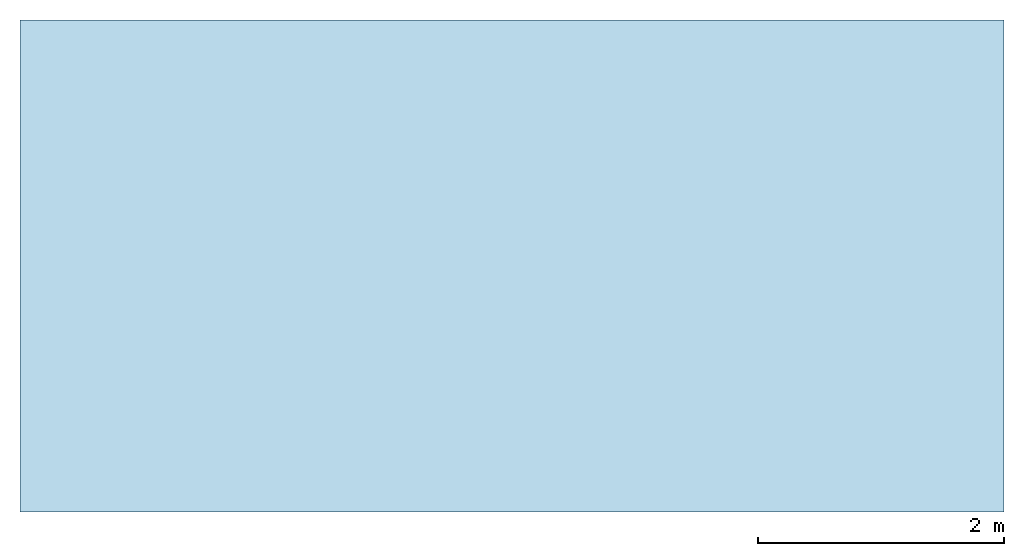
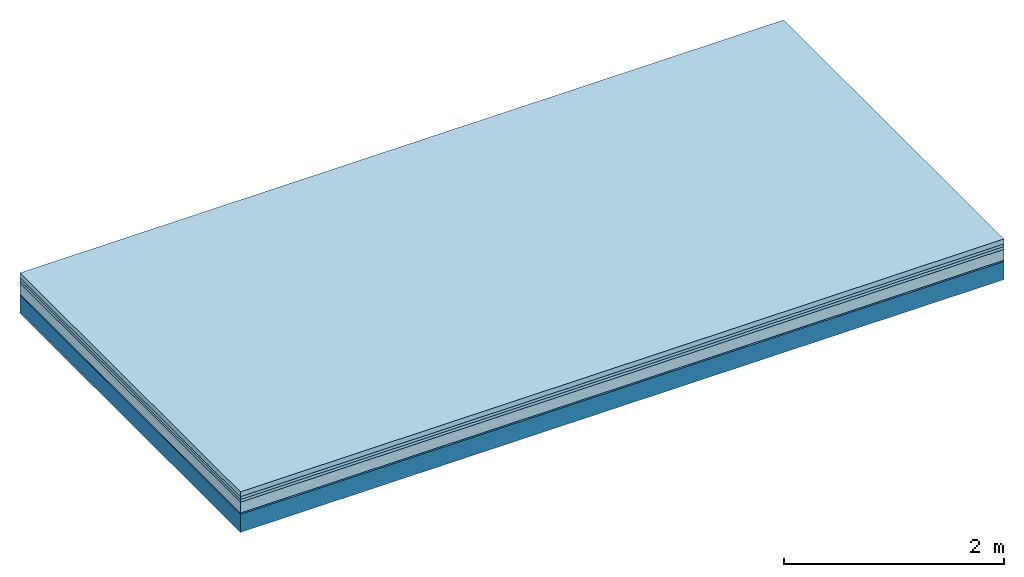
# One storey: 5 plates, 1 member, 1 element without a shape of its own.
"""IFC4 building model written with IfcOpenShell, lengths in metres."""

from ifc_helpers import new_model, si_unit, derived_unit, direction, frame, frame_2d, origin, origin_with_axes, place, context, project, spatial, rectangle, extrude, material, layer, layer_set, type_object, element, aggregate, save


model = new_model("IFC4")

# Units and contexts
plan_context = context("Plan", 3, precision=1e-05, world=origin(), true_north=direction((0.0, 1.0)))
model_context = context("Model", 3, precision=1e-05, world=origin(), true_north=direction((0.0, 1.0)))
ifc_project = project(units=[si_unit("LENGTHUNIT", "METRE"), derived_unit("SOUNDPRESSUREUNIT", [(si_unit("PRESSUREUNIT", "PASCAL", prefix="MICRO"), 0)]), si_unit("ENERGYUNIT", "JOULE", prefix="MEGA"), si_unit("MASSUNIT", "GRAM", prefix="KILO"), derived_unit("THERMALTRANSMITTANCEUNIT", [(si_unit("POWERUNIT", "WATT"), 1), (si_unit("AREAUNIT", "SQUARE_METRE"), -1), (si_unit("THERMODYNAMICTEMPERATUREUNIT", "KELVIN"), -1)]), derived_unit("AREADENSITYUNIT", [(si_unit("MASSUNIT", "GRAM", prefix="KILO"), 1), (si_unit("AREAUNIT", "SQUARE_METRE"), -1)]), derived_unit("USERDEFINED", [(si_unit("ENERGYUNIT", "JOULE", prefix="MEGA"), 1), (si_unit("AREAUNIT", "SQUARE_METRE"), -1)])], contexts=[plan_context, model_context])

# Site, building, storey
site = spatial("IfcSite", under=ifc_project)
building_placement = place(None, origin())
building = spatial("IfcBuilding", under=site, at=building_placement)
storey_placement = place(building_placement, origin())
storey = spatial("IfcBuildingStorey", under=building, at=storey_placement)

# Slab, member, plates
ifc_material_1 = material(Category="04.005")
ifc_layer_1 = layer(ifc_material_1, 0.055, Name="On-material")
ifc_material_2 = material()
ifc_layer_2 = layer(ifc_material_2, 0.03, Name="Impact sound insulation")
ifc_material_3 = material()
ifc_layer_3 = layer(ifc_material_3, 0.03, Name="Additional insulation")
ifc_material_4 = material(Category="03.011")
ifc_layer_4 = layer(ifc_material_4, 0.12, Name="on Supporting structure")
ifc_material_5 = material(Category="03.007")
ifc_layer_5 = layer(ifc_material_5, 0.015, Name="Sub-floor")
ifc_material_6 = material(Name="of the art")
ifc_layer_6 = layer(ifc_material_6, 0.0, Name="Bond")
ifc_layer_7 = layer(None, 0.2, Name="Supporting structure")
ifc_layer_set = layer_set([ifc_layer_1, ifc_layer_2, ifc_layer_3, ifc_layer_4, ifc_layer_5, ifc_layer_6, ifc_layer_7])
slab_type = type_object("IfcSlabType", Name="A1104", PredefinedType="NOTDEFINED", material=ifc_layer_set)
slab_placement = place(None, frame((0.0, 0.0, 0.0), z_axis=(0.0, 0.0, -1.0), x_axis=(1.0, 0.0, 0.0)))
slab = element("IfcSlab", 1, at=slab_placement, inside=storey, type_object=slab_type, material=ifc_layer_set, Name="Slab #1")
ifc_material_7 = material()
member_placement = place(slab_placement, origin())
member = element("IfcMember", 2, at=member_placement, material=ifc_material_7, Name="Supporting structure", context=plan_context, shape_type="SweptSolid", body=[
    extrude(rectangle(XDim=1.0, YDim=0.2, at=frame_2d((0.5, 0.1), x_axis=(1.0, 0.0))), frame((0.0, 4.0, 0.25), z_axis=(0.0, -1.0, 0.0), x_axis=(1.0, 0.0, 0.0)), (0.0, 0.0, 1.0), 4.0),
    extrude(rectangle(XDim=1.0, YDim=0.2, at=frame_2d((0.5, 0.1), x_axis=(1.0, 0.0))), frame((1.0, 4.0, 0.25), z_axis=(0.0, -1.0, 0.0), x_axis=(1.0, 0.0, 0.0)), (0.0, 0.0, 1.0), 4.0),
    extrude(rectangle(XDim=1.0, YDim=0.2, at=frame_2d((0.5, 0.1), x_axis=(1.0, 0.0))), frame((2.0, 4.0, 0.25), z_axis=(0.0, -1.0, 0.0), x_axis=(1.0, 0.0, 0.0)), (0.0, 0.0, 1.0), 4.0),
    extrude(rectangle(XDim=1.0, YDim=0.2, at=frame_2d((0.5, 0.1), x_axis=(1.0, 0.0))), frame((3.0, 4.0, 0.25), z_axis=(0.0, -1.0, 0.0), x_axis=(1.0, 0.0, 0.0)), (0.0, 0.0, 1.0), 4.0),
    extrude(rectangle(XDim=1.0, YDim=0.2, at=frame_2d((0.5, 0.1), x_axis=(1.0, 0.0))), frame((4.0, 4.0, 0.25), z_axis=(0.0, -1.0, 0.0), x_axis=(1.0, 0.0, 0.0)), (0.0, 0.0, 1.0), 4.0),
    extrude(rectangle(XDim=1.0, YDim=0.2, at=frame_2d((0.5, 0.1), x_axis=(1.0, 0.0))), frame((5.0, 4.0, 0.25), z_axis=(0.0, -1.0, 0.0), x_axis=(1.0, 0.0, 0.0)), (0.0, 0.0, 1.0), 4.0),
    extrude(rectangle(XDim=1.0, YDim=0.2, at=frame_2d((0.5, 0.1), x_axis=(1.0, 0.0))), frame((6.0, 4.0, 0.25), z_axis=(0.0, -1.0, 0.0), x_axis=(1.0, 0.0, 0.0)), (0.0, 0.0, 1.0), 4.0),
    extrude(rectangle(XDim=1.0, YDim=0.2, at=frame_2d((0.5, 0.1), x_axis=(1.0, 0.0))), frame((7.0, 4.0, 0.25), z_axis=(0.0, -1.0, 0.0), x_axis=(1.0, 0.0, 0.0)), (0.0, 0.0, 1.0), 4.0),
])
plate_1_placement = place(slab_placement, origin())
plate_1 = element("IfcPlate", 3, at=plate_1_placement, material=ifc_material_1, Name="On-material", context=plan_context, shape_type="SweptSolid", body=[
    extrude(rectangle(XDim=8.0, YDim=4.0, at=frame_2d((4.0, 2.0), x_axis=(1.0, 0.0))), origin_with_axes(), (0.0, 0.0, 1.0), 0.055),
])
plate_2_placement = place(slab_placement, origin())
plate_2 = element("IfcPlate", 4, at=plate_2_placement, material=ifc_material_2, Name="Impact sound insulation", context=plan_context, shape_type="SweptSolid", body=[
    extrude(rectangle(XDim=8.0, YDim=4.0, at=frame_2d((4.0, 2.0), x_axis=(1.0, 0.0))), frame((0.0, 0.0, 0.055), z_axis=(0.0, 0.0, 1.0), x_axis=(1.0, 0.0, 0.0)), (0.0, 0.0, 1.0), 0.03),
])
plate_3_placement = place(slab_placement, origin())
plate_3 = element("IfcPlate", 5, at=plate_3_placement, material=ifc_material_3, Name="Additional insulation", context=plan_context, shape_type="SweptSolid", body=[
    extrude(rectangle(XDim=8.0, YDim=4.0, at=frame_2d((4.0, 2.0), x_axis=(1.0, 0.0))), frame((0.0, 0.0, 0.085), z_axis=(0.0, 0.0, 1.0), x_axis=(1.0, 0.0, 0.0)), (0.0, 0.0, 1.0), 0.03),
])
plate_4_placement = place(slab_placement, origin())
plate_4 = element("IfcPlate", 6, at=plate_4_placement, material=ifc_material_4, Name="on Supporting structure", context=plan_context, shape_type="SweptSolid", body=[
    extrude(rectangle(XDim=8.0, YDim=4.0, at=frame_2d((4.0, 2.0), x_axis=(1.0, 0.0))), frame((0.0, 0.0, 0.115), z_axis=(0.0, 0.0, 1.0), x_axis=(1.0, 0.0, 0.0)), (0.0, 0.0, 1.0), 0.12),
])
plate_5_placement = place(slab_placement, origin())
plate_5 = element("IfcPlate", 7, at=plate_5_placement, material=ifc_material_5, Name="Sub-floor", context=plan_context, shape_type="SweptSolid", body=[
    extrude(rectangle(XDim=8.0, YDim=4.0, at=frame_2d((4.0, 2.0), x_axis=(1.0, 0.0))), frame((0.0, 0.0, 0.235), z_axis=(0.0, 0.0, 1.0), x_axis=(1.0, 0.0, 0.0)), (0.0, 0.0, 1.0), 0.015),
])
aggregate(slab, [plate_1, plate_2, plate_3, plate_4, plate_5, member])

save(model, "model.ifc")
